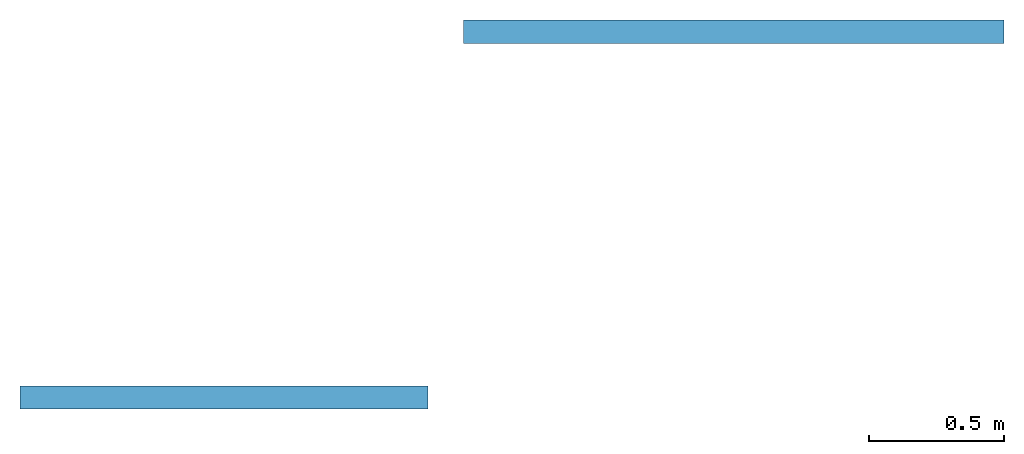
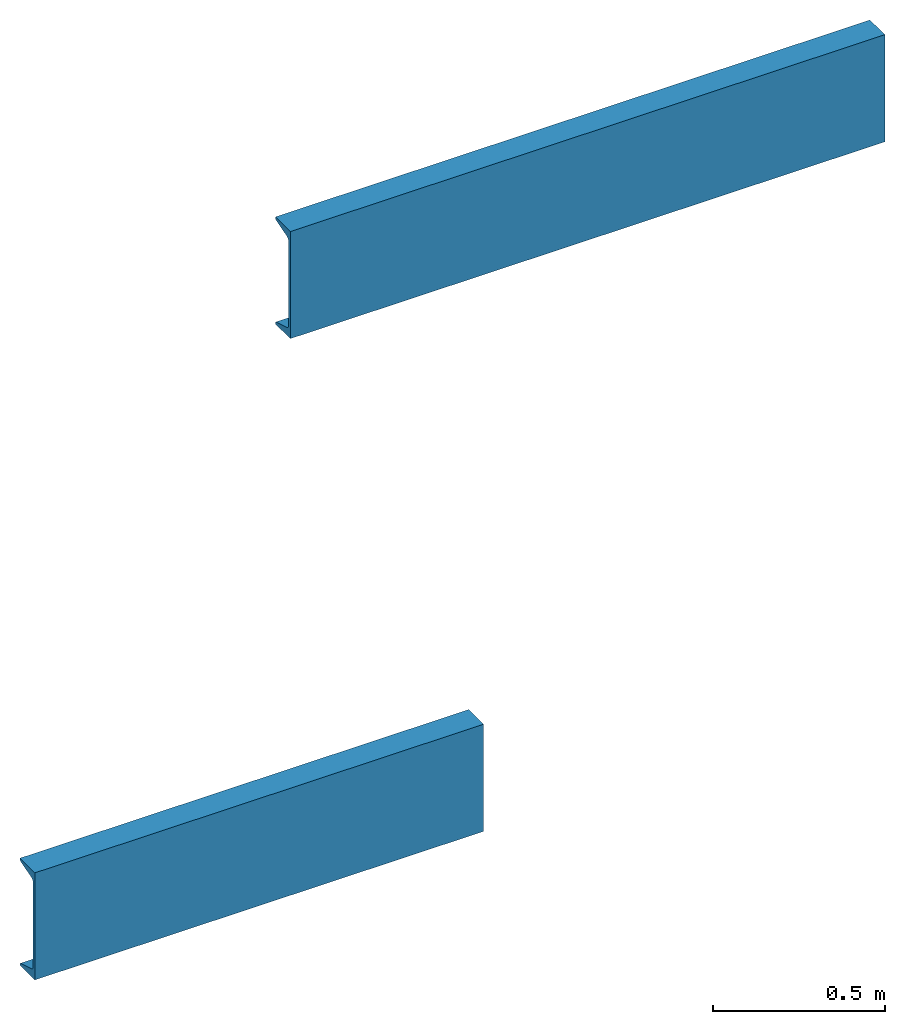
# One storey: 2 beams.
"""IFC4 building model written with IfcOpenShell, lengths in inches."""

from ifc_helpers import new_model, entity, si_unit, converted_unit, frame, frame_2d, origin_with_axes, place, context, subcontext, project, spatial, u_section, extrude, material, material_profile, profile_set, profile_usage, type_object, element, save


model = new_model("IFC4")

# Units and contexts
model_context = context("Model", 3, precision=1e-05, world=origin_with_axes())
plan_context = context("Plan", 2, precision=1e-05, world=frame_2d((0.0, 0.0, 0.0), x_axis=(1.0, 0.0, 0.0)))
body_context = subcontext(model_context, "Body", "Model", "MODEL_VIEW")
ifc_project = project(units=[converted_unit("LENGTHUNIT", "inch", entity("IfcReal", 0.0254), si_unit("LENGTHUNIT", "METRE"), dimensions=[1, 0, 0, 0, 0, 0, 0]), converted_unit("VOLUMEUNIT", "cubic inch", entity("IfcReal", 1.639e-05), si_unit("VOLUMEUNIT", "CUBIC_METRE"), dimensions=[3, 0, 0, 0, 0, 0, 0]), converted_unit("PLANEANGLEUNIT", "degree", entity("IfcReal", 0.0174532925199433), si_unit("PLANEANGLEUNIT", "RADIAN"), dimensions=[0, 0, 0, 0, 0, 0, 0]), converted_unit("AREAUNIT", "square inch", entity("IfcReal", 0.0006452), si_unit("AREAUNIT", "SQUARE_METRE"), dimensions=[2, 0, 0, 0, 0, 0, 0])], contexts=[model_context, plan_context])

# Site, building, storey
site_placement = place(None, origin_with_axes())
site = spatial("IfcSite", under=ifc_project, at=site_placement)
building_placement = place(site_placement, origin_with_axes())
building = spatial("IfcBuilding", under=site, at=building_placement, Name="Building")
storey_placement = place(building_placement, origin_with_axes())
storey = spatial("IfcBuildingStorey", under=building, at=storey_placement, Name="Storey")

# Beams
ifc_material = material(Name="C STEEL BEAM 1 MAT")
ifc_material_profile = material_profile(ifc_material, u_section(Depth=15.0, FlangeWidth=3.40000009536743, WebThickness=0.400000005960464, FlangeThickness=0.836000025272369, FilletRadius=0.5, EdgeRadius=0.239999994635582, FlangeSlope=16.6700000762939), Name="C STEEL BEAM 1")
ifc_profile_set = profile_set([ifc_material_profile], Name="C STEEL BEAM 1")
ifc_profile_usage_1 = profile_usage(ifc_profile_set)
beam_type = type_object("IfcBeamType", Name="C STEEL BEAM 1", PredefinedType="BEAM", material=ifc_profile_set)
beam_1_placement = place(storey_placement, frame((9.52097374623216, -107.594155889796, 5.51385907676276), z_axis=(1.0, 4.37113882867379e-08, -4.37113882867379e-08), x_axis=(-4.37113882867379e-08, 1.0, 0.0)))
element("IfcBeam", 1, at=beam_1_placement, inside=storey, type_object=beam_type, material=ifc_profile_usage_1, Name="Beam", context=body_context, shape_type="SweptSolid", body=[
    extrude(u_section(Depth=15.0, FlangeWidth=3.40000009536743, WebThickness=0.400000005960464, FlangeThickness=0.836000025272369, FilletRadius=0.5, EdgeRadius=0.239999994635582, FlangeSlope=16.6700000762939), None, (0.0, 0.0, 1.0), 78.740157480315),
])
ifc_profile_usage_2 = profile_usage(ifc_profile_set)
beam_2_placement = place(storey_placement, frame((-55.0729458726297, -160.871509491928, -29.3586901792391), z_axis=(1.0, 4.37113882867379e-08, -4.37113882867379e-08), x_axis=(-4.37113882867379e-08, 1.0, 0.0)))
element("IfcBeam", 2, at=beam_2_placement, inside=storey, type_object=beam_type, material=ifc_profile_usage_2, Name="Beam", context=body_context, shape_type="SweptSolid", body=[
    extrude(u_section(Depth=15.0, FlangeWidth=3.40000009536743, WebThickness=0.400000005960464, FlangeThickness=0.836000025272369, FilletRadius=0.5, EdgeRadius=0.239999994635582, FlangeSlope=16.6700000762939), None, (0.0, 0.0, 1.0), 59.416763425812),
])

save(model, "model.ifc")
